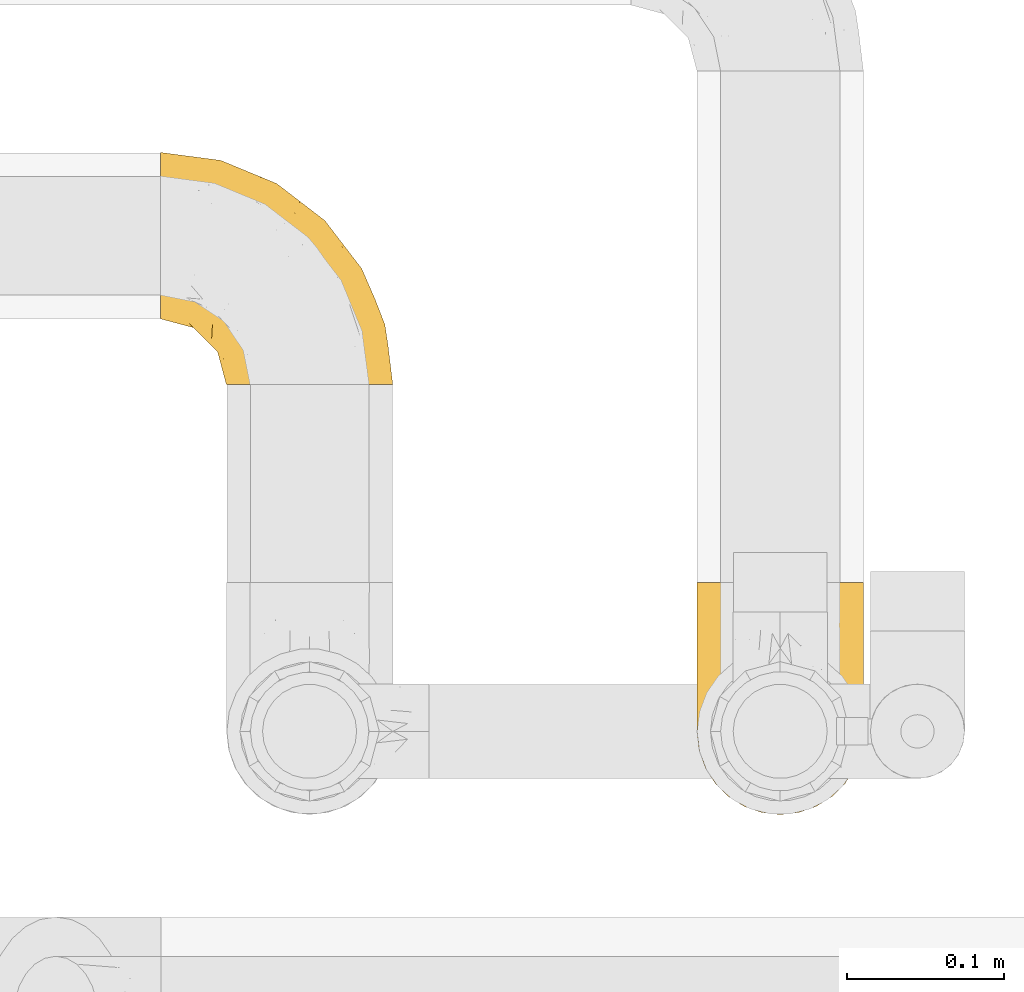
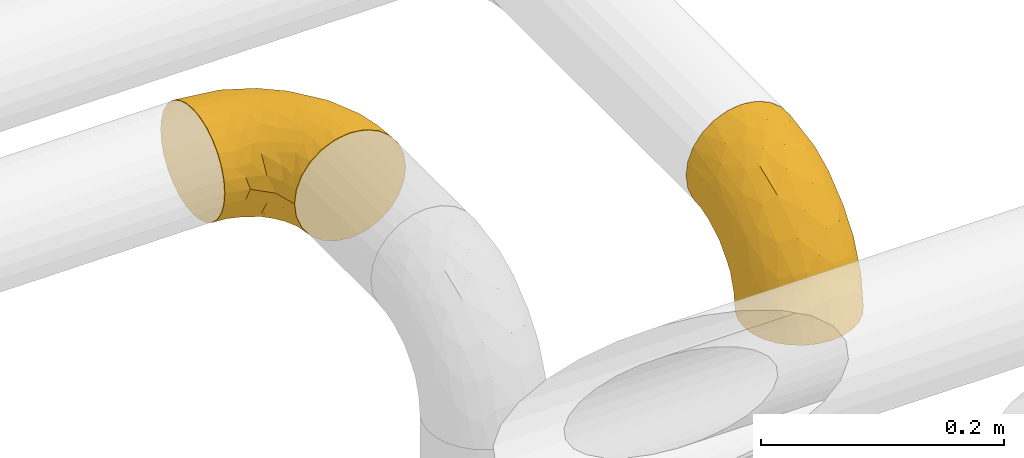
# One storey, part 411 of 827: 2 coverings.
"""IFC2X3 building model written with IfcOpenShell, lengths in millimetres."""

from ifc_helpers import new_model, entity, si_unit, converted_unit, derived_unit, direction, frame, origin, place, context, subcontext, project, spatial, faceted_brep, element, save


model = new_model("IFC2X3")

# Units and contexts
model_context = context("Model", 3, precision=0.01, world=origin(), true_north=direction((6.12303176911189e-17, 1.0)))
body_context = subcontext(model_context, "Body", "Model", "MODEL_VIEW")
ifc_project = project(units=[si_unit("LENGTHUNIT", "METRE", prefix="MILLI"), si_unit("AREAUNIT", "SQUARE_METRE"), si_unit("VOLUMEUNIT", "CUBIC_METRE"), converted_unit("PLANEANGLEUNIT", "DEGREE", entity("IfcRatioMeasure", 0.0174532925199433), si_unit("PLANEANGLEUNIT", "RADIAN"), dimensions=[0, 0, 0, 0, 0, 0, 0]), si_unit("MASSUNIT", "GRAM", prefix="KILO"), derived_unit("MASSDENSITYUNIT", [(si_unit("MASSUNIT", "GRAM", prefix="KILO"), 1), (si_unit("LENGTHUNIT", "METRE"), -3)]), derived_unit("MOMENTOFINERTIAUNIT", [(si_unit("LENGTHUNIT", "METRE"), 4)]), si_unit("TIMEUNIT", "SECOND"), si_unit("FREQUENCYUNIT", "HERTZ"), si_unit("THERMODYNAMICTEMPERATUREUNIT", "DEGREE_CELSIUS"), derived_unit("THERMALTRANSMITTANCEUNIT", [(si_unit("MASSUNIT", "GRAM", prefix="KILO"), 1), (si_unit("THERMODYNAMICTEMPERATUREUNIT", "KELVIN"), -1), (si_unit("TIMEUNIT", "SECOND"), -3)]), derived_unit("VOLUMETRICFLOWRATEUNIT", [(si_unit("LENGTHUNIT", "METRE"), 3), (si_unit("TIMEUNIT", "SECOND"), -1)]), derived_unit("MASSFLOWRATEUNIT", [(si_unit("MASSUNIT", "GRAM", prefix="KILO"), 1), (si_unit("TIMEUNIT", "SECOND"), -1)]), derived_unit("ROTATIONALFREQUENCYUNIT", [(si_unit("TIMEUNIT", "SECOND"), -1)]), si_unit("ELECTRICCURRENTUNIT", "AMPERE"), si_unit("ELECTRICVOLTAGEUNIT", "VOLT"), si_unit("POWERUNIT", "WATT"), si_unit("FORCEUNIT", "NEWTON", prefix="KILO"), si_unit("ILLUMINANCEUNIT", "LUX"), si_unit("LUMINOUSFLUXUNIT", "LUMEN"), si_unit("LUMINOUSINTENSITYUNIT", "CANDELA"), derived_unit("USERDEFINED", [(si_unit("MASSUNIT", "GRAM", prefix="KILO"), -1), (si_unit("LENGTHUNIT", "METRE"), -2), (si_unit("TIMEUNIT", "SECOND"), 3), (si_unit("LUMINOUSFLUXUNIT", "LUMEN"), 1)]), derived_unit("LINEARVELOCITYUNIT", [(si_unit("LENGTHUNIT", "METRE"), 1), (si_unit("TIMEUNIT", "SECOND"), -1)]), si_unit("PRESSUREUNIT", "PASCAL"), derived_unit("USERDEFINED", [(si_unit("LENGTHUNIT", "METRE"), -2), (si_unit("MASSUNIT", "GRAM", prefix="KILO"), 1), (si_unit("TIMEUNIT", "SECOND"), -2)]), derived_unit("LINEARFORCEUNIT", [(si_unit("MASSUNIT", "GRAM", prefix="KILO"), 1), (si_unit("LENGTHUNIT", "METRE"), 1), (si_unit("TIMEUNIT", "SECOND"), -2), (si_unit("LENGTHUNIT", "METRE"), -1)]), derived_unit("PLANARFORCEUNIT", [(si_unit("MASSUNIT", "GRAM", prefix="KILO"), 1), (si_unit("LENGTHUNIT", "METRE"), 1), (si_unit("TIMEUNIT", "SECOND"), -2), (si_unit("LENGTHUNIT", "METRE"), -2)])], contexts=[model_context])

# Site, building, storey
site_placement = place(None, origin())
site = spatial("IfcSite", under=ifc_project, at=site_placement, CompositionType="ELEMENT")
building_placement = place(site_placement, origin())
building = spatial("IfcBuilding", under=site, at=building_placement, CompositionType="ELEMENT")
storey_placement = place(building_placement, frame((0.0, 0.0, 28200.0)))
storey = spatial("IfcBuildingStorey", under=building, at=storey_placement, Name="08", CompositionType="ELEMENT", Elevation=28200.0)

# Coverings
covering_1_placement = place(storey_placement, frame((46411.22, 19210.64, 2945.35)))
element("IfcCovering", 1, at=covering_1_placement, inside=storey, Name=":ADSK_", ObjectType=":ADSK_", PredefinedType="INSULATION", context=body_context, shape_type="Brep", body=[
    faceted_brep([(1.6, 148.32, 66.44), (1.6, 149.65, 54.65), (1.6, 148.31, 42.84), (1.6, 144.39, 31.62), (1.6, 138.06, 21.56), (1.6, 129.66, 13.16), (1.6, 119.6, 6.84), (1.6, 108.39, 2.92), (1.6, 96.6, 1.6), (1.6, 84.79, 2.93), (1.6, 73.57, 6.85), (1.6, 63.51, 13.18), (1.6, 55.11, 21.58), (1.6, 48.79, 31.64), (1.6, 44.87, 42.85), (1.6, 43.55, 54.65), (1.6, 44.88, 66.46), (1.6, 48.8, 77.67), (1.6, 55.13, 87.73), (1.6, 63.53, 96.13), (1.6, 73.59, 102.45), (1.6, 84.8, 106.37), (1.6, 96.6, 107.7), (1.6, 108.41, 106.36), (1.6, 119.62, 102.44), (1.6, 129.68, 96.11), (1.6, 138.08, 87.71), (1.6, 144.4, 77.65), (45.35, 1.6, 40.91), (50.65, 1.6, 28.12), (59.08, 1.6, 17.13), (70.07, 1.6, 8.7), (82.86, 1.6, 3.4), (96.6, 1.6, 1.6), (110.33, 1.6, 3.4), (123.12, 1.6, 8.7), (134.11, 1.6, 17.13), (142.54, 1.6, 28.12), (147.84, 1.6, 40.91), (149.65, 1.6, 54.65), (147.84, 1.6, 68.38), (142.54, 1.6, 81.17), (134.11, 1.6, 92.16), (123.12, 1.6, 100.59), (110.33, 1.6, 105.89), (96.6, 1.6, 107.7), (82.86, 1.6, 105.89), (70.07, 1.6, 100.59), (59.08, 1.6, 92.16), (50.65, 1.6, 81.17), (45.35, 1.6, 68.38), (43.55, 1.6, 54.65), (137.19, 27.97, 85.53), (141.79, 37.09, 73.42), (128.89, 58.27, 83.77), (146.54, 27.13, 64.22), (144.6, 39.91, 54.65), (69.77, 109.11, 96.72), (94.41, 94.41, 93.36), (87.22, 110.94, 84.47), (117.2, 89.69, 71.37), (129.81, 75.62, 54.65), (106.28, 106.28, 54.65), (101.45, 60.12, 103.47), (115.81, 41.41, 100.91), (109.14, 63.22, 99.1), (107.65, 32.05, 105.43), (93.36, 52.13, 106.79), (59.44, 123.27, 89.81), (63.23, 129.32, 79.59), (35.59, 138.3, 81.29), (132.3, 62.95, 74.01), (138.41, 55.89, 64.14), (126.28, 37.4, 94.75), (39.91, 144.6, 54.65), (37.44, 142.66, 70.74), (90.35, 117.85, 68.3), (65.0, 134.01, 66.05), (85.4, 89.25, 100.73), (26.66, 103.34, 106.78), (29.88, 113.52, 103.6), (78.45, 57.43, 107.7), (85.2, 44.19, 107.7), (91.95, 30.95, 107.7), (77.98, 77.98, 106.07), (29.55, 132.66, 90.59), (41.42, 121.52, 97.43), (111.13, 86.93, 84.51), (114.67, 68.4, 93.3), (57.43, 78.45, 107.7), (67.94, 67.94, 107.7), (14.64, 94.53, 107.7), (30.95, 91.95, 107.7), (52.13, 93.36, 106.79), (44.19, 85.2, 107.7), (60.12, 101.45, 103.47), (75.62, 129.81, 54.65), (94.27, 16.27, 107.7), (24.59, 42.46, 76.99), (34.69, 40.4, 84.28), (31.15, 49.71, 91.11), (75.18, 39.4, 106.26), (67.55, 31.26, 102.6), (79.36, 27.7, 106.08), (84.32, 16.7, 106.56), (40.81, 70.67, 105.36), (29.93, 81.69, 106.74), (70.24, 16.68, 101.59), (37.93, 22.57, 54.65), (40.15, 14.26, 54.65), (42.1, 17.68, 67.71), (55.38, 19.58, 91.36), (52.17, 33.49, 94.33), (44.32, 33.01, 87.1), (19.85, 40.69, 65.84), (14.26, 40.15, 54.65), (22.57, 37.93, 54.65), (34.17, 31.04, 68.92), (54.85, 45.29, 100.82), (44.63, 23.55, 79.83), (47.52, 11.36, 77.13), (59.1, 59.1, 105.9), (44.11, 57.42, 101.53), (53.21, 68.96, 106.72), (62.86, 20.38, 97.75), (20.58, 72.46, 103.08), (15.79, 83.66, 106.39), (27.67, 60.66, 98.1), (13.49, 61.01, 95.02), (18.04, 51.85, 86.9), (12.44, 46.07, 74.42), (30.25, 30.25, 54.65), (66.71, 46.65, 105.28), (42.52, 43.0, 92.87), (55.38, 19.58, 17.93), (20.57, 72.44, 6.22), (42.11, 17.67, 41.58), (57.43, 78.45, 1.6), (53.22, 68.97, 2.57), (40.81, 70.65, 3.94), (19.85, 40.69, 43.46), (24.58, 42.45, 32.32), (34.16, 31.04, 40.38), (42.5, 42.99, 16.44), (54.93, 45.18, 8.47), (52.13, 33.46, 15.01), (27.66, 60.64, 11.21), (44.12, 57.37, 7.78), (78.45, 57.43, 1.6), (85.2, 44.19, 1.6), (75.17, 39.35, 3.04), (94.27, 16.27, 1.6), (84.32, 16.7, 2.73), (30.95, 91.95, 1.6), (44.19, 85.2, 1.6), (29.98, 81.68, 2.55), (66.78, 46.68, 3.98), (67.55, 31.26, 6.69), (70.24, 16.68, 7.7), (79.36, 27.7, 3.21), (13.48, 60.99, 14.28), (18.03, 51.84, 22.42), (34.66, 40.41, 25.02), (31.14, 49.72, 18.18), (12.43, 46.06, 34.89), (14.64, 94.53, 1.6), (47.52, 11.35, 32.17), (44.28, 33.02, 22.23), (15.8, 83.65, 2.91), (62.86, 20.38, 11.54), (67.94, 67.94, 1.6), (44.64, 23.53, 29.46), (59.12, 59.12, 3.38), (91.95, 30.95, 1.6), (128.89, 58.27, 25.52), (137.19, 27.97, 23.76), (126.28, 37.4, 14.54), (115.81, 41.41, 8.38), (146.53, 27.21, 45.07), (141.79, 37.09, 35.87), (139.45, 53.2, 45.14), (93.36, 52.13, 2.5), (26.67, 103.34, 2.51), (29.87, 113.5, 5.68), (60.12, 101.45, 5.82), (94.41, 94.41, 15.93), (69.76, 109.08, 12.54), (87.19, 110.95, 24.81), (52.13, 93.36, 2.5), (77.98, 77.98, 3.22), (107.65, 32.05, 3.86), (131.74, 64.63, 35.85), (59.44, 123.25, 19.47), (29.54, 132.65, 18.68), (63.2, 129.32, 29.68), (27.9, 139.96, 27.95), (90.35, 117.85, 40.99), (117.2, 89.69, 37.92), (41.39, 121.51, 11.85), (109.14, 63.23, 10.19), (85.46, 89.17, 8.55), (37.43, 142.66, 38.53), (114.67, 68.4, 15.99), (111.12, 86.94, 24.79), (101.45, 60.12, 5.82), (65.16, 133.2, 40.56)], [[[0, 1, 2, 3, 4, 5, 6, 7, 8, 9, 10, 11, 12, 13, 14, 15, 16, 17, 18, 19, 20, 21, 22, 23, 24, 25, 26, 27]], [[28, 29, 30, 31, 32, 33, 34, 35, 36, 37, 38, 39, 40, 41, 42, 43, 44, 45, 46, 47, 48, 49, 50, 51]], [[52, 53, 54]], [[55, 39, 56]], [[57, 58, 59]], [[60, 61, 62]], [[63, 64, 65]], [[66, 63, 67]], [[68, 69, 70]], [[53, 71, 54]], [[41, 40, 53]], [[53, 72, 71]], [[73, 42, 52]], [[42, 41, 52]], [[74, 0, 75]], [[69, 76, 77]], [[43, 73, 64]], [[45, 44, 66]], [[57, 78, 58]], [[23, 79, 80]], [[67, 81, 82, 83]], [[67, 84, 81]], [[24, 23, 80]], [[25, 85, 26]], [[86, 85, 25]], [[42, 73, 43]], [[0, 27, 75]], [[25, 24, 86]], [[70, 26, 85]], [[0, 74, 1]], [[68, 85, 86]], [[66, 64, 63]], [[60, 59, 87]], [[54, 87, 88]], [[76, 60, 62]], [[84, 89, 90, 81]], [[79, 22, 91, 92]], [[77, 74, 75]], [[93, 92, 94, 89]], [[80, 86, 24]], [[40, 55, 53]], [[76, 59, 60]], [[93, 84, 95]], [[76, 62, 96]], [[55, 72, 53]], [[70, 27, 26]], [[75, 70, 69]], [[78, 84, 63]], [[93, 79, 92]], [[95, 86, 80]], [[77, 76, 96]], [[59, 69, 68]], [[57, 68, 86]], [[68, 57, 59]], [[59, 58, 87]], [[76, 69, 59]], [[88, 87, 58]], [[87, 54, 71]], [[86, 95, 57]], [[78, 57, 95]], [[84, 78, 95]], [[78, 63, 65]], [[58, 78, 65]], [[54, 88, 73]], [[84, 93, 89]], [[79, 95, 80]], [[79, 93, 95]], [[22, 79, 23]], [[66, 83, 97, 45]], [[84, 67, 63]], [[83, 66, 67]], [[64, 44, 43]], [[64, 66, 44]], [[65, 73, 88]], [[53, 52, 41]], [[73, 52, 54]], [[73, 65, 64]], [[65, 88, 58]], [[39, 55, 40]], [[72, 55, 56]], [[56, 61, 72]], [[60, 72, 61]], [[72, 60, 71]], [[87, 71, 60]], [[27, 70, 75]], [[68, 70, 85]], [[74, 77, 96]], [[69, 77, 75]], [[98, 99, 100]], [[46, 45, 97]], [[101, 102, 103]], [[103, 104, 83]], [[105, 94, 106]], [[107, 103, 102]], [[108, 109, 51, 110]], [[111, 112, 113]], [[114, 115, 116]], [[47, 104, 107]], [[110, 117, 108]], [[49, 48, 111]], [[102, 118, 112]], [[119, 120, 111]], [[50, 49, 120]], [[121, 122, 118]], [[105, 123, 89]], [[124, 48, 107]], [[20, 19, 125]], [[121, 81, 90]], [[117, 119, 99]], [[21, 20, 126]], [[22, 21, 91]], [[105, 125, 127]], [[110, 51, 50]], [[19, 128, 125]], [[16, 15, 115]], [[129, 98, 100]], [[126, 91, 21]], [[128, 129, 127]], [[122, 123, 105]], [[114, 117, 98]], [[17, 16, 130]], [[18, 128, 19]], [[129, 18, 17]], [[125, 106, 126]], [[115, 114, 16]], [[130, 129, 17]], [[114, 98, 130]], [[117, 116, 131, 108]], [[99, 119, 113]], [[122, 121, 123]], [[92, 126, 106]], [[105, 127, 122]], [[132, 121, 118]], [[114, 130, 16]], [[129, 130, 98]], [[50, 120, 110]], [[129, 128, 18]], [[125, 128, 127]], [[125, 126, 20]], [[91, 126, 92]], [[105, 89, 94]], [[105, 106, 125]], [[94, 92, 106]], [[100, 122, 127]], [[118, 122, 133]], [[112, 118, 133]], [[132, 118, 102]], [[132, 102, 101]], [[81, 121, 132]], [[82, 103, 83]], [[132, 101, 81]], [[104, 47, 46]], [[124, 107, 102]], [[48, 47, 107]], [[113, 112, 133]], [[112, 111, 124]], [[99, 113, 133]], [[111, 113, 119]], [[99, 133, 100]], [[117, 99, 98]], [[122, 100, 133]], [[127, 129, 100]], [[103, 82, 101]], [[81, 101, 82]], [[112, 124, 102]], [[48, 124, 111]], [[104, 103, 107]], [[46, 97, 104]], [[111, 120, 49]], [[83, 104, 97]], [[110, 120, 119]], [[117, 110, 119]], [[116, 117, 114]], [[123, 90, 89]], [[90, 123, 121]], [[30, 29, 134]], [[11, 10, 135]], [[51, 109, 108, 136]], [[137, 138, 139]], [[140, 141, 142]], [[143, 144, 145]], [[146, 139, 147]], [[148, 149, 150]], [[151, 32, 152]], [[153, 154, 155]], [[156, 150, 157]], [[158, 157, 159]], [[108, 142, 136]], [[31, 158, 152]], [[160, 161, 12]], [[162, 163, 143]], [[140, 142, 116]], [[142, 141, 162]], [[14, 164, 140]], [[14, 140, 115]], [[9, 8, 165]], [[160, 12, 11]], [[141, 164, 161]], [[13, 12, 161]], [[14, 115, 15]], [[28, 166, 29]], [[135, 139, 146]], [[141, 163, 162]], [[135, 146, 160]], [[143, 167, 162]], [[29, 166, 134]], [[116, 142, 108, 131]], [[165, 153, 168]], [[10, 9, 168]], [[168, 135, 10]], [[138, 147, 139]], [[158, 169, 157]], [[14, 13, 164]], [[116, 115, 140]], [[145, 167, 143]], [[135, 160, 11]], [[168, 153, 155]], [[138, 137, 170]], [[157, 144, 156]], [[147, 144, 143]], [[161, 164, 13]], [[140, 164, 141]], [[142, 171, 136]], [[136, 171, 166]], [[161, 160, 146]], [[165, 168, 9]], [[155, 139, 135]], [[139, 154, 137]], [[168, 155, 135]], [[139, 155, 154]], [[144, 147, 172]], [[163, 147, 143]], [[156, 144, 172]], [[157, 169, 145]], [[172, 148, 156]], [[173, 159, 149]], [[159, 157, 150]], [[152, 159, 173]], [[159, 152, 158]], [[31, 30, 158]], [[169, 30, 134]], [[157, 145, 144]], [[167, 134, 171]], [[134, 167, 145]], [[171, 142, 162]], [[162, 167, 171]], [[163, 141, 161]], [[161, 146, 163]], [[147, 163, 146]], [[148, 150, 156]], [[149, 159, 150]], [[30, 169, 158]], [[145, 169, 134]], [[151, 33, 32]], [[31, 152, 32]], [[152, 173, 151]], [[28, 51, 136]], [[134, 166, 171]], [[28, 136, 166]], [[138, 170, 172]], [[147, 138, 172]], [[148, 172, 170]], [[174, 175, 176]], [[35, 34, 177]], [[178, 179, 180]], [[181, 173, 149, 148]], [[182, 183, 184]], [[185, 186, 187]], [[188, 189, 137]], [[190, 33, 151, 173]], [[191, 179, 174]], [[34, 190, 177]], [[39, 38, 178]], [[192, 193, 194]], [[4, 3, 195]], [[175, 179, 37]], [[38, 37, 179]], [[35, 176, 36]], [[196, 62, 197]], [[181, 190, 173]], [[37, 36, 175]], [[183, 6, 198]], [[189, 148, 170, 137]], [[185, 199, 200]], [[3, 2, 201]], [[202, 185, 203]], [[8, 7, 182]], [[200, 184, 186]], [[183, 7, 6]], [[181, 189, 204]], [[200, 189, 184]], [[5, 198, 6]], [[187, 203, 185]], [[195, 3, 201]], [[205, 196, 194]], [[62, 61, 197]], [[186, 198, 192]], [[180, 179, 191]], [[2, 1, 74]], [[198, 193, 192]], [[193, 5, 4]], [[194, 193, 195]], [[2, 74, 201]], [[5, 193, 198]], [[205, 74, 96]], [[188, 137, 154, 153]], [[62, 196, 96]], [[56, 178, 180]], [[198, 184, 183]], [[184, 188, 182]], [[203, 197, 191]], [[205, 194, 201]], [[187, 192, 194]], [[192, 187, 186]], [[194, 196, 187]], [[197, 187, 196]], [[197, 203, 187]], [[202, 174, 176]], [[200, 186, 185]], [[184, 198, 186]], [[199, 185, 202]], [[189, 200, 204]], [[174, 202, 203]], [[176, 177, 199]], [[189, 181, 148]], [[190, 181, 204]], [[190, 204, 177]], [[190, 34, 33]], [[188, 153, 182]], [[189, 188, 184]], [[182, 153, 165, 8]], [[183, 182, 7]], [[199, 177, 204]], [[35, 177, 176]], [[176, 175, 36]], [[179, 175, 174]], [[200, 199, 204]], [[176, 199, 202]], [[203, 191, 174]], [[180, 197, 61]], [[197, 180, 191]], [[61, 56, 180]], [[39, 178, 56]], [[38, 179, 178]], [[194, 195, 201]], [[4, 195, 193]], [[74, 205, 201]], [[96, 196, 205]]]),
])
covering_2_placement = place(storey_placement, frame((46753.17, 18936.58, 2903.4)))
element("IfcCovering", 2, at=covering_2_placement, inside=storey, Name=":ADSK_", ObjectType=":ADSK_", PredefinedType="INSULATION", context=body_context, shape_type="Brep", body=[
    faceted_brep([(66.44, 2.92, 1.6), (54.65, 1.6, 1.6), (42.84, 2.93, 1.6), (31.62, 6.85, 1.6), (21.56, 13.18, 1.6), (13.16, 21.58, 1.6), (6.84, 31.64, 1.6), (2.92, 42.85, 1.6), (1.6, 54.65, 1.6), (2.93, 66.46, 1.6), (6.85, 77.67, 1.6), (13.18, 87.73, 1.6), (21.58, 96.13, 1.6), (31.64, 102.45, 1.6), (42.85, 106.37, 1.6), (54.65, 107.7, 1.6), (66.46, 106.36, 1.6), (77.67, 102.44, 1.6), (87.73, 96.11, 1.6), (96.13, 87.71, 1.6), (102.45, 77.65, 1.6), (106.37, 66.44, 1.6), (107.7, 54.65, 1.6), (106.36, 42.84, 1.6), (102.44, 31.62, 1.6), (96.11, 21.56, 1.6), (87.71, 13.16, 1.6), (77.65, 6.84, 1.6), (40.91, 149.65, 45.35), (28.12, 149.65, 50.65), (17.13, 149.65, 59.08), (8.7, 149.65, 70.07), (3.4, 149.65, 82.86), (1.6, 149.65, 96.6), (3.4, 149.65, 110.33), (8.7, 149.65, 123.12), (17.13, 149.65, 134.11), (28.12, 149.65, 142.54), (40.91, 149.65, 147.84), (54.65, 149.65, 149.65), (68.38, 149.65, 147.84), (81.17, 149.65, 142.54), (92.16, 149.65, 134.11), (100.59, 149.65, 123.12), (105.89, 149.65, 110.33), (107.7, 149.65, 96.6), (105.89, 149.65, 82.86), (100.59, 149.65, 70.07), (92.16, 149.65, 59.08), (81.17, 149.65, 50.65), (68.38, 149.65, 45.35), (54.65, 149.65, 43.55), (85.53, 123.27, 137.19), (73.42, 114.15, 141.79), (83.77, 92.97, 128.89), (64.22, 124.11, 146.54), (54.65, 111.33, 144.6), (96.72, 42.13, 69.77), (93.36, 56.83, 94.41), (84.47, 40.31, 87.22), (71.37, 61.55, 117.2), (54.65, 75.62, 129.81), (54.65, 44.96, 106.28), (103.47, 91.12, 101.45), (100.91, 109.83, 115.81), (99.1, 88.02, 109.14), (105.43, 119.19, 107.65), (106.79, 99.11, 93.36), (89.81, 27.97, 59.44), (79.59, 21.92, 63.23), (81.29, 12.94, 35.59), (74.01, 88.29, 132.3), (64.14, 95.35, 138.41), (94.75, 113.84, 126.28), (54.65, 6.64, 39.91), (70.74, 8.58, 37.44), (68.3, 33.39, 90.35), (66.05, 17.23, 65.0), (100.73, 61.99, 85.4), (106.78, 47.9, 26.66), (103.6, 37.72, 29.88), (107.7, 93.81, 78.45), (107.7, 107.05, 85.2), (107.7, 120.29, 91.95), (106.07, 73.26, 77.98), (90.59, 18.58, 29.55), (97.43, 29.72, 41.42), (84.51, 64.31, 111.13), (93.3, 82.84, 114.67), (107.7, 72.79, 57.43), (107.7, 83.3, 67.94), (107.7, 56.71, 14.64), (107.7, 59.29, 30.95), (106.79, 57.88, 52.13), (107.7, 66.04, 44.19), (103.47, 49.8, 60.12), (54.65, 21.43, 75.62), (107.7, 134.97, 94.27), (76.99, 108.79, 24.59), (84.28, 110.84, 34.69), (91.11, 101.53, 31.15), (106.26, 111.84, 75.18), (102.6, 119.98, 67.55), (106.08, 123.54, 79.36), (106.56, 134.54, 84.32), (105.36, 80.57, 40.81), (106.74, 69.55, 29.93), (101.59, 134.56, 70.24), (54.65, 128.67, 37.93), (54.65, 136.98, 40.15), (67.71, 133.56, 42.1), (91.36, 131.66, 55.38), (94.33, 117.75, 52.17), (87.1, 118.23, 44.32), (65.84, 110.55, 19.85), (54.65, 111.09, 14.26), (54.65, 113.32, 22.57), (68.92, 120.2, 34.17), (100.82, 105.95, 54.85), (79.83, 127.69, 44.63), (77.13, 139.88, 47.52), (105.9, 92.14, 59.1), (101.53, 93.82, 44.11), (106.72, 82.28, 53.21), (97.75, 130.86, 62.86), (103.08, 78.78, 20.58), (106.39, 67.58, 15.79), (98.1, 90.58, 27.67), (95.02, 90.23, 13.49), (86.9, 99.39, 18.04), (74.42, 105.17, 12.44), (54.65, 120.99, 30.25), (105.28, 104.59, 66.71), (92.87, 108.24, 42.52), (17.93, 131.66, 55.38), (6.22, 78.8, 20.57), (41.58, 133.57, 42.11), (1.6, 72.79, 57.43), (2.57, 82.27, 53.22), (3.94, 80.59, 40.81), (43.46, 110.55, 19.85), (32.32, 108.79, 24.58), (40.38, 120.2, 34.16), (16.44, 108.25, 42.5), (8.47, 106.06, 54.93), (15.01, 117.78, 52.13), (11.21, 90.6, 27.66), (7.78, 93.87, 44.12), (1.6, 93.81, 78.45), (1.6, 107.05, 85.2), (3.04, 111.89, 75.17), (1.6, 134.97, 94.27), (2.73, 134.54, 84.32), (1.6, 59.29, 30.95), (1.6, 66.04, 44.19), (2.55, 69.56, 29.98), (3.98, 104.56, 66.78), (6.69, 119.98, 67.55), (7.7, 134.56, 70.24), (3.21, 123.54, 79.36), (14.28, 90.25, 13.48), (22.42, 99.4, 18.03), (25.02, 110.83, 34.66), (18.18, 101.52, 31.14), (34.89, 105.18, 12.43), (1.6, 56.71, 14.64), (32.17, 139.89, 47.52), (22.23, 118.22, 44.28), (2.91, 67.6, 15.8), (11.54, 130.86, 62.86), (1.6, 83.3, 67.94), (29.46, 127.71, 44.64), (3.38, 92.12, 59.12), (1.6, 120.29, 91.95), (25.52, 92.97, 128.89), (23.76, 123.27, 137.19), (14.54, 113.84, 126.28), (8.38, 109.83, 115.81), (45.07, 124.03, 146.53), (35.87, 114.15, 141.79), (45.14, 98.04, 139.45), (2.5, 99.11, 93.36), (2.51, 47.9, 26.67), (5.68, 37.74, 29.87), (5.82, 49.8, 60.12), (15.93, 56.83, 94.41), (12.54, 42.16, 69.76), (24.81, 40.3, 87.19), (2.5, 57.88, 52.13), (3.22, 73.26, 77.98), (3.86, 119.19, 107.65), (35.85, 86.61, 131.74), (19.47, 27.99, 59.44), (18.68, 18.59, 29.54), (29.68, 21.92, 63.2), (27.95, 11.28, 27.9), (40.99, 33.39, 90.35), (37.92, 61.55, 117.2), (11.85, 29.73, 41.39), (10.19, 88.01, 109.14), (8.55, 62.08, 85.46), (38.53, 8.58, 37.43), (15.99, 82.84, 114.67), (24.79, 64.3, 111.12), (5.82, 91.12, 101.45), (40.56, 18.05, 65.16)], [[[0, 1, 2, 3, 4, 5, 6, 7, 8, 9, 10, 11, 12, 13, 14, 15, 16, 17, 18, 19, 20, 21, 22, 23, 24, 25, 26, 27]], [[28, 29, 30, 31, 32, 33, 34, 35, 36, 37, 38, 39, 40, 41, 42, 43, 44, 45, 46, 47, 48, 49, 50, 51]], [[52, 53, 54]], [[55, 39, 56]], [[57, 58, 59]], [[60, 61, 62]], [[63, 64, 65]], [[66, 63, 67]], [[68, 69, 70]], [[53, 71, 54]], [[41, 40, 53]], [[53, 72, 71]], [[73, 42, 52]], [[42, 41, 52]], [[74, 0, 75]], [[69, 76, 77]], [[43, 73, 64]], [[45, 44, 66]], [[57, 78, 58]], [[23, 79, 80]], [[67, 81, 82, 83]], [[67, 84, 81]], [[24, 23, 80]], [[25, 85, 26]], [[86, 85, 25]], [[42, 73, 43]], [[0, 27, 75]], [[25, 24, 86]], [[70, 26, 85]], [[0, 74, 1]], [[68, 85, 86]], [[66, 64, 63]], [[60, 59, 87]], [[54, 87, 88]], [[76, 60, 62]], [[84, 89, 90, 81]], [[79, 22, 91, 92]], [[77, 74, 75]], [[93, 92, 94, 89]], [[80, 86, 24]], [[40, 55, 53]], [[76, 59, 60]], [[93, 84, 95]], [[76, 62, 96]], [[55, 72, 53]], [[70, 27, 26]], [[75, 70, 69]], [[78, 84, 63]], [[93, 79, 92]], [[95, 86, 80]], [[77, 76, 96]], [[59, 69, 68]], [[57, 68, 86]], [[68, 57, 59]], [[59, 58, 87]], [[76, 69, 59]], [[88, 87, 58]], [[87, 54, 71]], [[86, 95, 57]], [[78, 57, 95]], [[84, 78, 95]], [[78, 63, 65]], [[58, 78, 65]], [[54, 88, 73]], [[84, 93, 89]], [[79, 95, 80]], [[79, 93, 95]], [[22, 79, 23]], [[66, 83, 97, 45]], [[84, 67, 63]], [[83, 66, 67]], [[64, 44, 43]], [[64, 66, 44]], [[65, 73, 88]], [[53, 52, 41]], [[73, 52, 54]], [[73, 65, 64]], [[65, 88, 58]], [[39, 55, 40]], [[72, 55, 56]], [[56, 61, 72]], [[60, 72, 61]], [[72, 60, 71]], [[87, 71, 60]], [[27, 70, 75]], [[68, 70, 85]], [[74, 77, 96]], [[69, 77, 75]], [[98, 99, 100]], [[46, 45, 97]], [[101, 102, 103]], [[103, 104, 83]], [[105, 94, 106]], [[107, 103, 102]], [[108, 109, 51, 110]], [[111, 112, 113]], [[114, 115, 116]], [[47, 104, 107]], [[110, 117, 108]], [[49, 48, 111]], [[102, 118, 112]], [[119, 120, 111]], [[50, 49, 120]], [[121, 122, 118]], [[105, 123, 89]], [[124, 48, 107]], [[20, 19, 125]], [[121, 81, 90]], [[117, 119, 99]], [[21, 20, 126]], [[22, 21, 91]], [[105, 125, 127]], [[110, 51, 50]], [[19, 128, 125]], [[16, 15, 115]], [[129, 98, 100]], [[126, 91, 21]], [[128, 129, 127]], [[122, 123, 105]], [[114, 117, 98]], [[17, 16, 130]], [[18, 128, 19]], [[129, 18, 17]], [[125, 106, 126]], [[115, 114, 16]], [[130, 129, 17]], [[114, 98, 130]], [[117, 116, 131, 108]], [[99, 119, 113]], [[122, 121, 123]], [[92, 126, 106]], [[105, 127, 122]], [[132, 121, 118]], [[114, 130, 16]], [[129, 130, 98]], [[50, 120, 110]], [[129, 128, 18]], [[125, 128, 127]], [[125, 126, 20]], [[91, 126, 92]], [[105, 89, 94]], [[105, 106, 125]], [[94, 92, 106]], [[100, 122, 127]], [[118, 122, 133]], [[112, 118, 133]], [[132, 118, 102]], [[132, 102, 101]], [[81, 121, 132]], [[82, 103, 83]], [[132, 101, 81]], [[104, 47, 46]], [[124, 107, 102]], [[48, 47, 107]], [[113, 112, 133]], [[112, 111, 124]], [[99, 113, 133]], [[111, 113, 119]], [[99, 133, 100]], [[117, 99, 98]], [[122, 100, 133]], [[127, 129, 100]], [[103, 82, 101]], [[81, 101, 82]], [[112, 124, 102]], [[48, 124, 111]], [[104, 103, 107]], [[46, 97, 104]], [[111, 120, 49]], [[83, 104, 97]], [[110, 120, 119]], [[117, 110, 119]], [[116, 117, 114]], [[89, 123, 90]], [[90, 123, 121]], [[30, 29, 134]], [[11, 10, 135]], [[51, 109, 108, 136]], [[137, 138, 139]], [[140, 141, 142]], [[143, 144, 145]], [[146, 139, 147]], [[148, 149, 150]], [[151, 32, 152]], [[153, 154, 155]], [[156, 150, 157]], [[158, 157, 159]], [[108, 142, 136]], [[31, 158, 152]], [[160, 161, 12]], [[162, 163, 143]], [[140, 142, 116]], [[142, 141, 162]], [[14, 164, 140]], [[14, 140, 115]], [[9, 8, 165]], [[160, 12, 11]], [[141, 164, 161]], [[13, 12, 161]], [[14, 115, 15]], [[28, 166, 29]], [[135, 139, 146]], [[141, 163, 162]], [[135, 146, 160]], [[143, 167, 162]], [[29, 166, 134]], [[116, 142, 108, 131]], [[165, 153, 168]], [[10, 9, 168]], [[168, 135, 10]], [[138, 147, 139]], [[158, 169, 157]], [[14, 13, 164]], [[116, 115, 140]], [[145, 167, 143]], [[135, 160, 11]], [[168, 153, 155]], [[138, 137, 170]], [[157, 144, 156]], [[147, 144, 143]], [[161, 164, 13]], [[140, 164, 141]], [[142, 171, 136]], [[136, 171, 166]], [[161, 160, 146]], [[165, 168, 9]], [[155, 139, 135]], [[139, 154, 137]], [[168, 155, 135]], [[139, 155, 154]], [[144, 147, 172]], [[163, 147, 143]], [[156, 144, 172]], [[157, 169, 145]], [[172, 148, 156]], [[173, 159, 149]], [[159, 157, 150]], [[152, 159, 173]], [[159, 152, 158]], [[31, 30, 158]], [[169, 30, 134]], [[157, 145, 144]], [[167, 134, 171]], [[134, 167, 145]], [[171, 142, 162]], [[162, 167, 171]], [[163, 141, 161]], [[161, 146, 163]], [[147, 163, 146]], [[148, 150, 156]], [[149, 159, 150]], [[30, 169, 158]], [[145, 169, 134]], [[151, 33, 32]], [[31, 152, 32]], [[152, 173, 151]], [[28, 51, 136]], [[134, 166, 171]], [[28, 136, 166]], [[138, 170, 172]], [[147, 138, 172]], [[148, 172, 170]], [[174, 175, 176]], [[35, 34, 177]], [[178, 179, 180]], [[181, 173, 149, 148]], [[182, 183, 184]], [[185, 186, 187]], [[188, 189, 137]], [[190, 33, 151, 173]], [[191, 179, 174]], [[34, 190, 177]], [[39, 38, 178]], [[192, 193, 194]], [[4, 3, 195]], [[175, 179, 37]], [[38, 37, 179]], [[35, 176, 36]], [[196, 62, 197]], [[181, 190, 173]], [[37, 36, 175]], [[183, 6, 198]], [[189, 148, 170, 137]], [[185, 199, 200]], [[3, 2, 201]], [[202, 185, 203]], [[8, 7, 182]], [[200, 184, 186]], [[183, 7, 6]], [[181, 189, 204]], [[200, 189, 184]], [[5, 198, 6]], [[187, 203, 185]], [[195, 3, 201]], [[205, 196, 194]], [[62, 61, 197]], [[186, 198, 192]], [[180, 179, 191]], [[2, 1, 74]], [[198, 193, 192]], [[193, 5, 4]], [[194, 193, 195]], [[2, 74, 201]], [[5, 193, 198]], [[205, 74, 96]], [[188, 137, 154, 153]], [[62, 196, 96]], [[56, 178, 180]], [[198, 184, 183]], [[184, 188, 182]], [[203, 197, 191]], [[205, 194, 201]], [[187, 192, 194]], [[192, 187, 186]], [[194, 196, 187]], [[197, 187, 196]], [[197, 203, 187]], [[202, 174, 176]], [[200, 186, 185]], [[184, 198, 186]], [[199, 185, 202]], [[189, 200, 204]], [[174, 202, 203]], [[176, 177, 199]], [[189, 181, 148]], [[190, 181, 204]], [[190, 204, 177]], [[190, 34, 33]], [[188, 153, 182]], [[189, 188, 184]], [[182, 153, 165, 8]], [[183, 182, 7]], [[199, 177, 204]], [[35, 177, 176]], [[176, 175, 36]], [[179, 175, 174]], [[200, 199, 204]], [[176, 199, 202]], [[203, 191, 174]], [[180, 197, 61]], [[197, 180, 191]], [[61, 56, 180]], [[39, 178, 56]], [[38, 179, 178]], [[194, 195, 201]], [[4, 195, 193]], [[74, 205, 201]], [[96, 196, 205]]]),
])

save(model, "model.ifc")
